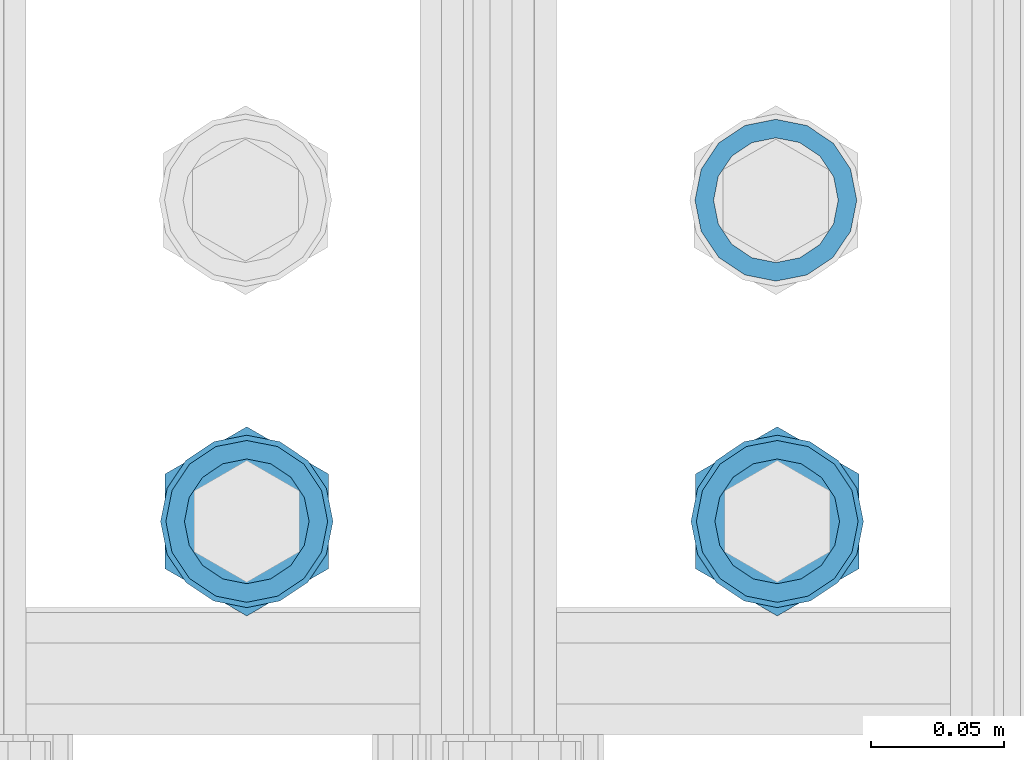
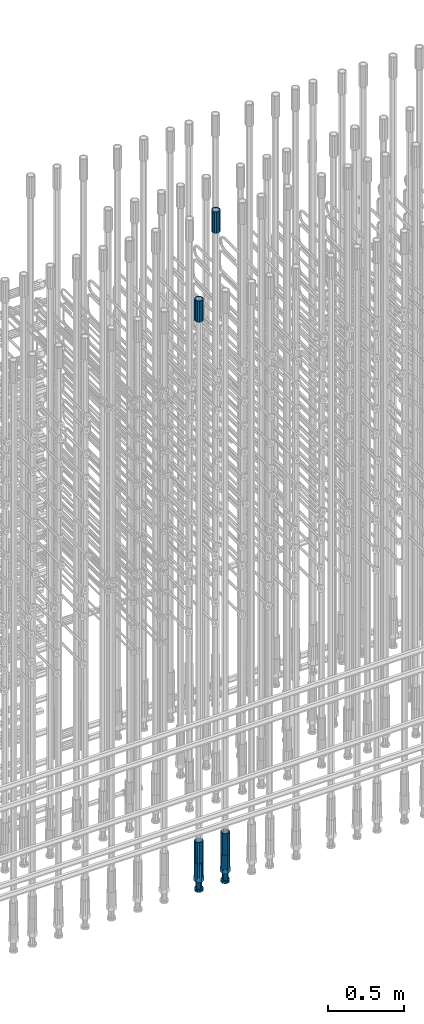
# One storey, part 59 of 177: 6 beams.
"""IFC2X3 building model written with IfcOpenShell, lengths in millimetres."""

from ifc_helpers import new_model, si_unit, frame, origin_with_axes, place, context, subcontext, project, spatial, faceted_brep, material, type_object, element, save


model = new_model("IFC2X3")

# Units and contexts
model_context_1 = context("Model", 3, precision=1e-05, world=origin_with_axes())
model_context_2 = context("Model", 3, precision=1e-05, world=origin_with_axes())
body_context = subcontext(model_context_2, "Body", "Model", "MODEL_VIEW")
ifc_project = project(units=[si_unit("LENGTHUNIT", "METRE", prefix="MILLI"), si_unit("AREAUNIT", "SQUARE_METRE"), si_unit("VOLUMEUNIT", "CUBIC_METRE"), si_unit("MASSUNIT", "GRAM", prefix="KILO"), si_unit("TIMEUNIT", "SECOND"), si_unit("PLANEANGLEUNIT", "RADIAN"), si_unit("SOLIDANGLEUNIT", "STERADIAN"), si_unit("THERMODYNAMICTEMPERATUREUNIT", "DEGREE_CELSIUS"), si_unit("LUMINOUSINTENSITYUNIT", "LUMEN")], contexts=[model_context_1])

# Site, building, storey
site_placement = place(None, origin_with_axes())
site = spatial("IfcSite", under=ifc_project, at=site_placement, CompositionType="ELEMENT")
building_placement = place(site_placement, origin_with_axes())
building = spatial("IfcBuilding", under=site, at=building_placement, Name="Undefined", CompositionType="ELEMENT")
storey_placement = place(building_placement, origin_with_axes())
storey = spatial("IfcBuildingStorey", under=building, at=storey_placement, Name="Undefined", CompositionType="ELEMENT", Elevation=0.0)

# Beams
ifc_material = material(Name="STEEL/S275")
beam_type_1 = type_object("IfcBeamType", PredefinedType="NOTDEFINED")
beam_1_placement = place(storey_placement, frame((2032435.50306268, 6205277.49272666, 23229.9858194793), z_axis=(1.0, 0.0, 0.0), x_axis=(0.0, 0.0, 1.0)))
element("IfcBeam", 1, at=beam_1_placement, inside=storey, type_object=beam_type_1, material=ifc_material, Name="AG40N", context=body_context, shape_type="Brep", body=[
    faceted_brep([(0.0, -23.5000000001164, -9.31322574615479e-10), (0.0, -21.7111690140155, 8.99306066054851), (170.0, -21.7111690140155, 8.99306066054851), (170.0, -23.5, 0.0), (0.0, -16.6170093578839, 16.6170093575493), (170.0, -16.6170093578839, 16.6170093575493), (0.0, -8.99306066057943, 21.7111690137535), (170.0, -8.99306066057943, 21.7111690137535), (0.0, 1.16415321826935e-10, 23.5), (170.0, 0.0, 23.5), (0.0, 8.99306066057943, 21.7111690137535), (170.0, 8.99306066057943, 21.7111690137535), (0.0, 16.6170093578839, 16.6170093575493), (170.0, 16.6170093578839, 16.6170093575493), (0.0, 21.7111690140155, 8.99306066054851), (170.0, 21.7111690140155, 8.99306066054851), (0.0, 23.5000000001164, -9.31322574615479e-10), (170.0, 23.5, 0.0), (0.0, 21.7111690140155, -8.99306066054851), (170.0, 21.7111690140155, -8.99306066054851), (0.0, 16.6170093578839, -16.6170093575493), (170.0, 16.6170093578839, -16.6170093575493), (0.0, 8.99306066057943, -21.7111690137535), (170.0, 8.99306066057943, -21.7111690137535), (0.0, 1.16415321826935e-10, -23.5000000009313), (170.0, 0.0, -23.5), (0.0, -8.99306066057943, -21.7111690137535), (170.0, -8.99306066057943, -21.7111690137535), (0.0, -16.6170093578839, -16.6170093575493), (170.0, -16.6170093578839, -16.6170093575493), (0.0, -21.7111690140155, -8.99306066054851), (170.0, -21.7111690140155, -8.99306066054851), (0.0, -30.5, 0.0), (0.0, -28.1783257415937, -11.6718446873128), (170.0, -28.1783257415937, -11.6718446873128), (170.0, -30.5, 0.0), (0.0, -21.5667568261888, -21.5667568258941), (170.0, -21.5667568261888, -21.5667568258941), (0.0, -11.6718446871346, -28.1783257415518), (170.0, -11.6718446871346, -28.1783257415518), (0.0, 0.0, -30.5), (170.0, 0.0, -30.5), (0.0, 11.6718446871346, -28.1783257415518), (170.0, 11.6718446871346, -28.1783257415518), (0.0, 21.5667568261888, -21.5667568258941), (170.0, 21.5667568261888, -21.5667568258941), (0.0, 28.1783257415937, -11.6718446873128), (170.0, 28.1783257415937, -11.6718446873128), (0.0, 30.5, 0.0), (170.0, 30.5, 0.0), (0.0, 28.1783257415937, 11.6718446873128), (170.0, 28.1783257415937, 11.6718446873128), (0.0, 21.5667568261888, 21.5667568258941), (170.0, 21.5667568261888, 21.5667568258941), (0.0, 11.6718446871346, 28.1783257415518), (170.0, 11.6718446871346, 28.1783257415518), (0.0, 0.0, 30.5), (170.0, 0.0, 30.5), (0.0, -11.6718446871346, 28.1783257415518), (170.0, -11.6718446871346, 28.1783257415518), (0.0, -21.5667568261888, 21.5667568258941), (170.0, -21.5667568261888, 21.5667568258941), (0.0, -28.1783257415937, 11.6718446873128), (170.0, -28.1783257415937, 11.6718446873128)], [[[0, 1, 2, 3]], [[1, 4, 5, 2]], [[4, 6, 7, 5]], [[6, 8, 9, 7]], [[8, 10, 11, 9]], [[10, 12, 13, 11]], [[12, 14, 15, 13]], [[14, 16, 17, 15]], [[16, 18, 19, 17]], [[18, 20, 21, 19]], [[20, 22, 23, 21]], [[22, 24, 25, 23]], [[24, 26, 27, 25]], [[26, 28, 29, 27]], [[28, 30, 31, 29]], [[30, 0, 3, 31]], [[32, 33, 34, 35]], [[33, 36, 37, 34]], [[36, 38, 39, 37]], [[38, 40, 41, 39]], [[40, 42, 43, 41]], [[42, 44, 45, 43]], [[44, 46, 47, 45]], [[46, 48, 49, 47]], [[48, 50, 51, 49]], [[50, 52, 53, 51]], [[52, 54, 55, 53]], [[54, 56, 57, 55]], [[56, 58, 59, 57]], [[58, 60, 61, 59]], [[60, 62, 63, 61]], [[62, 32, 35, 63]], [[37, 39, 41, 43, 45, 47, 49, 51, 53, 55, 57, 59, 61, 63, 35, 34], [5, 7, 9, 11, 13, 15, 17, 19, 21, 23, 25, 27, 29, 31, 3, 2]], [[62, 60, 58, 56, 54, 52, 50, 48, 46, 44, 42, 40, 38, 36, 33, 32], [30, 28, 26, 24, 22, 20, 18, 16, 14, 12, 10, 8, 6, 4, 1, 0]]]),
])
beam_2_placement = place(storey_placement, frame((2032236.00256268, 6205156.4084753, 18490.9668004282), z_axis=(-1.0, 0.0, 0.0), x_axis=(0.0, 0.0, -1.0)))
element("IfcBeam", 2, at=beam_2_placement, inside=storey, type_object=beam_type_1, material=ifc_material, Name="AG40N", context=body_context, shape_type="Brep", body=[
    faceted_brep([(0.0, -23.5000000001164, -9.31322574615479e-10), (0.0, -21.7111690140155, 8.99306066054851), (170.0, -21.7111690140155, 8.99306066054851), (170.0, -23.5, 0.0), (0.0, -16.6170093578839, 16.6170093575493), (170.0, -16.6170093578839, 16.6170093575493), (0.0, -8.99306066057943, 21.7111690137535), (170.0, -8.99306066057943, 21.7111690137535), (0.0, 1.16415321826935e-10, 23.5), (170.0, 0.0, 23.5), (0.0, 8.99306066057943, 21.7111690137535), (170.0, 8.99306066057943, 21.7111690137535), (0.0, 16.6170093578839, 16.6170093575493), (170.0, 16.6170093578839, 16.6170093575493), (0.0, 21.7111690140155, 8.99306066054851), (170.0, 21.7111690140155, 8.99306066054851), (0.0, 23.5000000001164, -9.31322574615479e-10), (170.0, 23.5, 0.0), (0.0, 21.7111690140155, -8.99306066054851), (170.0, 21.7111690140155, -8.99306066054851), (0.0, 16.6170093578839, -16.6170093575493), (170.0, 16.6170093578839, -16.6170093575493), (0.0, 8.99306066057943, -21.7111690137535), (170.0, 8.99306066057943, -21.7111690137535), (0.0, 1.16415321826935e-10, -23.5000000009313), (170.0, 0.0, -23.5), (0.0, -8.99306066057943, -21.7111690137535), (170.0, -8.99306066057943, -21.7111690137535), (0.0, -16.6170093578839, -16.6170093575493), (170.0, -16.6170093578839, -16.6170093575493), (0.0, -21.7111690140155, -8.99306066054851), (170.0, -21.7111690140155, -8.99306066054851), (0.0, -30.5, 0.0), (0.0, -28.1783257415937, -11.6718446873128), (170.0, -28.1783257415937, -11.6718446873128), (170.0, -30.5, 0.0), (0.0, -21.5667568261888, -21.5667568258941), (170.0, -21.5667568261888, -21.5667568258941), (0.0, -11.6718446871346, -28.1783257415518), (170.0, -11.6718446871346, -28.1783257415518), (0.0, 0.0, -30.5), (170.0, 0.0, -30.5), (0.0, 11.6718446871346, -28.1783257415518), (170.0, 11.6718446871346, -28.1783257415518), (0.0, 21.5667568261888, -21.5667568258941), (170.0, 21.5667568261888, -21.5667568258941), (0.0, 28.1783257415937, -11.6718446873128), (170.0, 28.1783257415937, -11.6718446873128), (0.0, 30.5, 0.0), (170.0, 30.5, 0.0), (0.0, 28.1783257415937, 11.6718446873128), (170.0, 28.1783257415937, 11.6718446873128), (0.0, 21.5667568261888, 21.5667568258941), (170.0, 21.5667568261888, 21.5667568258941), (0.0, 11.6718446871346, 28.1783257415518), (170.0, 11.6718446871346, 28.1783257415518), (0.0, 0.0, 30.5), (170.0, 0.0, 30.5), (0.0, -11.6718446871346, 28.1783257415518), (170.0, -11.6718446871346, 28.1783257415518), (0.0, -21.5667568261888, 21.5667568258941), (170.0, -21.5667568261888, 21.5667568258941), (0.0, -28.1783257415937, 11.6718446873128), (170.0, -28.1783257415937, 11.6718446873128)], [[[0, 1, 2, 3]], [[1, 4, 5, 2]], [[4, 6, 7, 5]], [[6, 8, 9, 7]], [[8, 10, 11, 9]], [[10, 12, 13, 11]], [[12, 14, 15, 13]], [[14, 16, 17, 15]], [[16, 18, 19, 17]], [[18, 20, 21, 19]], [[20, 22, 23, 21]], [[22, 24, 25, 23]], [[24, 26, 27, 25]], [[26, 28, 29, 27]], [[28, 30, 31, 29]], [[30, 0, 3, 31]], [[32, 33, 34, 35]], [[33, 36, 37, 34]], [[36, 38, 39, 37]], [[38, 40, 41, 39]], [[40, 42, 43, 41]], [[42, 44, 45, 43]], [[44, 46, 47, 45]], [[46, 48, 49, 47]], [[48, 50, 51, 49]], [[50, 52, 53, 51]], [[52, 54, 55, 53]], [[54, 56, 57, 55]], [[56, 58, 59, 57]], [[58, 60, 61, 59]], [[60, 62, 63, 61]], [[62, 32, 35, 63]], [[37, 39, 41, 43, 45, 47, 49, 51, 53, 55, 57, 59, 61, 63, 35, 34], [5, 7, 9, 11, 13, 15, 17, 19, 21, 23, 25, 27, 29, 31, 3, 2]], [[62, 60, 58, 56, 54, 52, 50, 48, 46, 44, 42, 40, 38, 36, 33, 32], [30, 28, 26, 24, 22, 20, 18, 16, 14, 12, 10, 8, 6, 4, 1, 0]]]),
])
beam_3_placement = place(storey_placement, frame((2032236.00256267, 6205156.40847529, 22659.9858194828), z_axis=(1.0, 0.0, 0.0), x_axis=(0.0, 0.0, 1.0)))
element("IfcBeam", 3, at=beam_3_placement, inside=storey, type_object=beam_type_1, material=ifc_material, Name="AG40N", context=body_context, shape_type="Brep", body=[
    faceted_brep([(0.0, -23.5000000001164, -9.31322574615479e-10), (0.0, -21.7111690140155, 8.99306066054851), (170.0, -21.7111690140155, 8.99306066054851), (170.0, -23.5, 0.0), (0.0, -16.6170093578839, 16.6170093575493), (170.0, -16.6170093578839, 16.6170093575493), (0.0, -8.99306066057943, 21.7111690137535), (170.0, -8.99306066057943, 21.7111690137535), (0.0, 1.16415321826935e-10, 23.5), (170.0, 0.0, 23.5), (0.0, 8.99306066057943, 21.7111690137535), (170.0, 8.99306066057943, 21.7111690137535), (0.0, 16.6170093578839, 16.6170093575493), (170.0, 16.6170093578839, 16.6170093575493), (0.0, 21.7111690140155, 8.99306066054851), (170.0, 21.7111690140155, 8.99306066054851), (0.0, 23.5000000001164, -9.31322574615479e-10), (170.0, 23.5, 0.0), (0.0, 21.7111690140155, -8.99306066054851), (170.0, 21.7111690140155, -8.99306066054851), (0.0, 16.6170093578839, -16.6170093575493), (170.0, 16.6170093578839, -16.6170093575493), (0.0, 8.99306066057943, -21.7111690137535), (170.0, 8.99306066057943, -21.7111690137535), (0.0, 1.16415321826935e-10, -23.5000000009313), (170.0, 0.0, -23.5), (0.0, -8.99306066057943, -21.7111690137535), (170.0, -8.99306066057943, -21.7111690137535), (0.0, -16.6170093578839, -16.6170093575493), (170.0, -16.6170093578839, -16.6170093575493), (0.0, -21.7111690140155, -8.99306066054851), (170.0, -21.7111690140155, -8.99306066054851), (0.0, -30.5, 0.0), (0.0, -28.1783257415937, -11.6718446873128), (170.0, -28.1783257415937, -11.6718446873128), (170.0, -30.5, 0.0), (0.0, -21.5667568261888, -21.5667568258941), (170.0, -21.5667568261888, -21.5667568258941), (0.0, -11.6718446871346, -28.1783257415518), (170.0, -11.6718446871346, -28.1783257415518), (0.0, 0.0, -30.5), (170.0, 0.0, -30.5), (0.0, 11.6718446871346, -28.1783257415518), (170.0, 11.6718446871346, -28.1783257415518), (0.0, 21.5667568261888, -21.5667568258941), (170.0, 21.5667568261888, -21.5667568258941), (0.0, 28.1783257415937, -11.6718446873128), (170.0, 28.1783257415937, -11.6718446873128), (0.0, 30.5, 0.0), (170.0, 30.5, 0.0), (0.0, 28.1783257415937, 11.6718446873128), (170.0, 28.1783257415937, 11.6718446873128), (0.0, 21.5667568261888, 21.5667568258941), (170.0, 21.5667568261888, 21.5667568258941), (0.0, 11.6718446871346, 28.1783257415518), (170.0, 11.6718446871346, 28.1783257415518), (0.0, 0.0, 30.5), (170.0, 0.0, 30.5), (0.0, -11.6718446871346, 28.1783257415518), (170.0, -11.6718446871346, 28.1783257415518), (0.0, -21.5667568261888, 21.5667568258941), (170.0, -21.5667568261888, 21.5667568258941), (0.0, -28.1783257415937, 11.6718446873128), (170.0, -28.1783257415937, 11.6718446873128)], [[[0, 1, 2, 3]], [[1, 4, 5, 2]], [[4, 6, 7, 5]], [[6, 8, 9, 7]], [[8, 10, 11, 9]], [[10, 12, 13, 11]], [[12, 14, 15, 13]], [[14, 16, 17, 15]], [[16, 18, 19, 17]], [[18, 20, 21, 19]], [[20, 22, 23, 21]], [[22, 24, 25, 23]], [[24, 26, 27, 25]], [[26, 28, 29, 27]], [[28, 30, 31, 29]], [[30, 0, 3, 31]], [[32, 33, 34, 35]], [[33, 36, 37, 34]], [[36, 38, 39, 37]], [[38, 40, 41, 39]], [[40, 42, 43, 41]], [[42, 44, 45, 43]], [[44, 46, 47, 45]], [[46, 48, 49, 47]], [[48, 50, 51, 49]], [[50, 52, 53, 51]], [[52, 54, 55, 53]], [[54, 56, 57, 55]], [[56, 58, 59, 57]], [[58, 60, 61, 59]], [[60, 62, 63, 61]], [[62, 32, 35, 63]], [[37, 39, 41, 43, 45, 47, 49, 51, 53, 55, 57, 59, 61, 63, 35, 34], [5, 7, 9, 11, 13, 15, 17, 19, 21, 23, 25, 27, 29, 31, 3, 2]], [[62, 60, 58, 56, 54, 52, 50, 48, 46, 44, 42, 40, 38, 36, 33, 32], [30, 28, 26, 24, 22, 20, 18, 16, 14, 12, 10, 8, 6, 4, 1, 0]]]),
])
beam_4_placement = place(storey_placement, frame((2032436.00256268, 6205156.4084753, 18490.9668004282), z_axis=(-1.0, 0.0, 0.0), x_axis=(0.0, 0.0, -1.0)))
element("IfcBeam", 4, at=beam_4_placement, inside=storey, type_object=beam_type_1, material=ifc_material, Name="AG40N", context=body_context, shape_type="Brep", body=[
    faceted_brep([(0.0, -23.5000000001164, -9.31322574615479e-10), (0.0, -21.7111690140155, 8.99306066054851), (170.0, -21.7111690140155, 8.99306066054851), (170.0, -23.5, 0.0), (0.0, -16.6170093578839, 16.6170093575493), (170.0, -16.6170093578839, 16.6170093575493), (0.0, -8.99306066057943, 21.7111690137535), (170.0, -8.99306066057943, 21.7111690137535), (0.0, 1.16415321826935e-10, 23.5), (170.0, 0.0, 23.5), (0.0, 8.99306066057943, 21.7111690137535), (170.0, 8.99306066057943, 21.7111690137535), (0.0, 16.6170093578839, 16.6170093575493), (170.0, 16.6170093578839, 16.6170093575493), (0.0, 21.7111690140155, 8.99306066054851), (170.0, 21.7111690140155, 8.99306066054851), (0.0, 23.5000000001164, -9.31322574615479e-10), (170.0, 23.5, 0.0), (0.0, 21.7111690140155, -8.99306066054851), (170.0, 21.7111690140155, -8.99306066054851), (0.0, 16.6170093578839, -16.6170093575493), (170.0, 16.6170093578839, -16.6170093575493), (0.0, 8.99306066057943, -21.7111690137535), (170.0, 8.99306066057943, -21.7111690137535), (0.0, 1.16415321826935e-10, -23.5000000009313), (170.0, 0.0, -23.5), (0.0, -8.99306066057943, -21.7111690137535), (170.0, -8.99306066057943, -21.7111690137535), (0.0, -16.6170093578839, -16.6170093575493), (170.0, -16.6170093578839, -16.6170093575493), (0.0, -21.7111690140155, -8.99306066054851), (170.0, -21.7111690140155, -8.99306066054851), (0.0, -30.5, 0.0), (0.0, -28.1783257415937, -11.6718446873128), (170.0, -28.1783257415937, -11.6718446873128), (170.0, -30.5, 0.0), (0.0, -21.5667568261888, -21.5667568258941), (170.0, -21.5667568261888, -21.5667568258941), (0.0, -11.6718446871346, -28.1783257415518), (170.0, -11.6718446871346, -28.1783257415518), (0.0, 0.0, -30.5), (170.0, 0.0, -30.5), (0.0, 11.6718446871346, -28.1783257415518), (170.0, 11.6718446871346, -28.1783257415518), (0.0, 21.5667568261888, -21.5667568258941), (170.0, 21.5667568261888, -21.5667568258941), (0.0, 28.1783257415937, -11.6718446873128), (170.0, 28.1783257415937, -11.6718446873128), (0.0, 30.5, 0.0), (170.0, 30.5, 0.0), (0.0, 28.1783257415937, 11.6718446873128), (170.0, 28.1783257415937, 11.6718446873128), (0.0, 21.5667568261888, 21.5667568258941), (170.0, 21.5667568261888, 21.5667568258941), (0.0, 11.6718446871346, 28.1783257415518), (170.0, 11.6718446871346, 28.1783257415518), (0.0, 0.0, 30.5), (170.0, 0.0, 30.5), (0.0, -11.6718446871346, 28.1783257415518), (170.0, -11.6718446871346, 28.1783257415518), (0.0, -21.5667568261888, 21.5667568258941), (170.0, -21.5667568261888, 21.5667568258941), (0.0, -28.1783257415937, 11.6718446873128), (170.0, -28.1783257415937, 11.6718446873128)], [[[0, 1, 2, 3]], [[1, 4, 5, 2]], [[4, 6, 7, 5]], [[6, 8, 9, 7]], [[8, 10, 11, 9]], [[10, 12, 13, 11]], [[12, 14, 15, 13]], [[14, 16, 17, 15]], [[16, 18, 19, 17]], [[18, 20, 21, 19]], [[20, 22, 23, 21]], [[22, 24, 25, 23]], [[24, 26, 27, 25]], [[26, 28, 29, 27]], [[28, 30, 31, 29]], [[30, 0, 3, 31]], [[32, 33, 34, 35]], [[33, 36, 37, 34]], [[36, 38, 39, 37]], [[38, 40, 41, 39]], [[40, 42, 43, 41]], [[42, 44, 45, 43]], [[44, 46, 47, 45]], [[46, 48, 49, 47]], [[48, 50, 51, 49]], [[50, 52, 53, 51]], [[52, 54, 55, 53]], [[54, 56, 57, 55]], [[56, 58, 59, 57]], [[58, 60, 61, 59]], [[60, 62, 63, 61]], [[62, 32, 35, 63]], [[37, 39, 41, 43, 45, 47, 49, 51, 53, 55, 57, 59, 61, 63, 35, 34], [5, 7, 9, 11, 13, 15, 17, 19, 21, 23, 25, 27, 29, 31, 3, 2]], [[62, 60, 58, 56, 54, 52, 50, 48, 46, 44, 42, 40, 38, 36, 33, 32], [30, 28, 26, 24, 22, 20, 18, 16, 14, 12, 10, 8, 6, 4, 1, 0]]]),
])
beam_type_2 = type_object("IfcBeamType", Name="ROD65", PredefinedType="NOTDEFINED")
beam_5_placement = place(storey_placement, frame((2032236.00256267, 6205156.4084753, 18320.9668004282), z_axis=(-1.0, 0.0, 0.0), x_axis=(0.0, 0.0, -1.0)))
element("IfcBeam", 5, at=beam_5_placement, inside=storey, type_object=beam_type_2, material=ifc_material, Name="AGB40", ObjectType="ROD65", context=body_context, shape_type="Brep", body=[
    faceted_brep([(117.0, 8.17543110251427, 30.873805644922), (117.0, 17.8250000001863, 30.873805644922), (117.0, 22.0056958701462, 23.6326279877685), (117.0, 12.4372115517035, 30.0260848065373), (117.0, -17.8250000001863, 30.873805644922), (150.200000000186, -17.8250000001863, 30.873805644922), (150.200000000186, 17.8250000001863, 30.873805644922), (117.0, -8.17543110251427, 30.873805644922), (117.0, -12.4372115517035, 30.0260848065373), (117.0, -22.0056958701462, 23.6326279877685), (117.0, -35.6500000003725, 0.0), (150.200000000186, -35.6500000003725, 0.0), (117.0, -30.8443150008097, 8.32369058486074), (117.0, -32.5, 0.0), (117.0, -30.8443150008097, -8.32369058462791), (117.0, -17.8250000001863, -30.873805644922), (150.200000000186, -17.8250000001863, -30.873805644922), (117.0, -22.0056958701462, -23.6326279877685), (117.0, -12.4372115517035, -30.0260848065373), (117.0, -8.17543110251427, -30.873805644922), (117.0, 17.8250000001863, -30.873805644922), (150.200000000186, 17.8250000001863, -30.873805644922), (117.0, 8.17543110251427, -30.873805644922), (117.0, 22.0056958701462, -23.6326279877685), (117.0, 12.4372115517035, -30.0260848065373), (117.0, 35.6500000003725, 0.0), (150.200000000186, 35.6500000003725, 0.0), (117.0, 30.8443150008097, -8.32369058486074), (117.0, 30.8443150008097, 8.32369058462791), (117.0, 32.5, 0.0), (0.0, -22.9809703892097, 22.9809703885621), (0.0, -30.0260848058388, 12.4372115518636), (117.0, -30.0260848067701, 12.4372115519363), (117.0, -22.9809703882784, 22.9809703885112), (-2.3283064365387e-10, 22.9809703892097, -22.9809703885639), (-4.65661287307739e-10, 30.0260848077014, -12.4372115518672), (117.0, 30.0260848067701, -12.4372115519363), (117.0, 22.9809703882784, -22.9809703885112), (-2.3283064365387e-10, -30.0260848067701, -12.4372115518672), (-2.3283064365387e-10, -22.9809703892097, -22.9809703885621), (117.0, -22.9809703882784, -22.9809703885112), (117.0, -30.0260848067701, -12.4372115519363), (-2.3283064365387e-10, -12.4372115507722, 30.0260848066137), (-2.3283064365387e-10, 9.31322574615479e-10, 32.4999999999982), (-2.3283064365387e-10, 12.4372115526348, 30.0260848066137), (0.0, 22.9809703892097, 22.9809703885621), (-2.3283064365387e-10, 30.0260848077014, 12.4372115518636), (-2.3283064365387e-10, 32.5, 0.0), (-2.3283064365387e-10, 12.4372115526348, -30.0260848066173), (-2.3283064365387e-10, 9.31322574615479e-10, -32.5), (-2.3283064365387e-10, -12.4372115517035, -30.0260848066173), (-4.65661287307739e-10, -32.4999999990687, -1.81898940354586e-12), (117.0, 22.9809703882784, 22.9809703885112), (117.0, 30.0260848067701, 12.4372115519363), (117.0, 0.0, -32.5), (117.0, 0.0, 32.5), (150.200000000186, 10.5, -18.1865334794857), (150.200000000186, 0.0, -21.0), (150.200000000186, -10.5, -18.1865334794857), (150.200000000186, -18.18653347902, -10.5), (150.200000000186, -21.0, 0.0), (150.200000000186, -18.18653347902, 10.5), (150.200000000186, -10.5, 18.1865334794857), (150.200000000186, 0.0, 21.0), (150.200000000186, 10.5, 18.1865334794857), (150.200000000186, 18.18653347902, 10.5), (150.200000000186, 21.0, 0.0), (150.200000000186, 18.18653347902, -10.5), (210.980000000447, -10.5, -18.1865334794857), (210.980000000447, 0.0, -21.0), (210.980000000447, -18.18653347902, -10.5), (210.980000000447, -21.0, 0.0), (210.980000000447, -18.18653347902, 10.5), (210.980000000447, -10.5, 18.1865334794857), (210.980000000447, 0.0, 21.0), (210.980000000447, 10.5, 18.1865334794857), (210.980000000447, 18.18653347902, 10.5), (210.980000000447, 21.0, 0.0), (210.980000000447, 18.18653347902, -10.5), (210.980000000447, 10.5, -18.1865334794857), (211.001368442696, -27.7269937992096, -11.491116326768), (211.003082550167, -21.2238094303757, -21.223815418547), (231.002518367059, -21.2131944671273, -21.2132004550658), (231.000804259587, -27.7163788359612, -11.4805013632867), (211.001368440451, -11.4911085031927, -27.7269970395137), (231.000804257343, -11.4804935399443, -27.7163820760325), (210.996487071217, -0.0106065049767494, -30.0106107392348), (230.995922888109, 8.45827162265778e-06, -29.9999957757536), (210.989181586672, 11.46989420522, -27.7269970329944), (230.988617403564, 11.4805091684684, -27.7163820695132), (210.980564180623, 21.2025914648548, -21.2238154064398), (230.979999997515, 21.2132064281031, -21.2132004429586), (210.971946775022, 27.7057703435421, -11.4911163107026), (230.971382591913, 27.7163853067905, -11.4805013472214), (210.96464129175, 29.9893808094785, -0.0106149562634528), (230.964077108642, 29.9999957727268, 7.21774995326996e-09), (210.959759924415, 27.7057638689876, 11.4698863970116), (230.959195741307, 27.7163788322359, 11.4805013604928), (210.958045816944, 21.2025795001537, 21.2025854887906), (230.957481633835, 21.213194463402, 21.2132004522718), (210.95975992666, 11.4698785729706, 27.7057671097573), (230.959195743551, 11.480493536219, 27.7163820732385), (210.964641295894, -0.010623425245285, 29.9893808094785), (230.964077112785, -8.46199691295624e-06, 29.9999957729597), (210.971946780439, -11.4911241354421, 27.705767103238), (230.97138259733, -11.4805091721937, 27.7163820667192), (210.980564186488, -21.2238213950768, 21.2025854766835), (230.980000003379, -21.2132064318284, 21.2132004401647), (210.989181592089, -27.7270002737641, 11.4698863809463), (230.988617408981, -27.7163853105158, 11.4805013444275), (210.996487075361, -30.0106107397005, -0.0106149734929204), (230.995922892253, -29.9999957764521, -1.00117176771164e-08)], [[[0, 1, 2, 3]], [[4, 5, 6, 1, 0, 7]], [[4, 7, 8, 9]], [[10, 11, 5, 4, 9, 12]], [[10, 12, 13, 14]], [[15, 16, 11, 10, 14, 17]], [[15, 17, 18, 19]], [[20, 21, 16, 15, 19, 22]], [[23, 20, 22, 24]], [[25, 26, 21, 20, 23, 27]], [[28, 25, 27, 29]], [[30, 31, 32, 33]], [[34, 35, 36, 37]], [[38, 39, 40, 41]], [[31, 30, 42, 43, 44, 45, 46, 47, 35, 34, 48, 49, 50, 39, 38, 51]], [[46, 45, 52, 53]], [[29, 47, 46, 53, 28]], [[27, 36, 35, 47, 29]], [[23, 37, 36, 27]], [[24, 48, 34, 37, 23]], [[22, 54, 49, 48, 24]], [[19, 54, 22]], [[18, 50, 49, 54, 19]], [[17, 40, 39, 50, 18]], [[14, 41, 40, 17]], [[13, 51, 38, 41, 14]], [[12, 32, 31, 51, 13]], [[9, 33, 32, 12]], [[8, 42, 30, 33, 9]], [[7, 55, 43, 42, 8]], [[0, 55, 7]], [[3, 44, 43, 55, 0]], [[2, 52, 45, 44, 3]], [[28, 53, 52, 2]], [[1, 6, 26, 25, 28, 2]], [[5, 11, 16, 21, 26, 6], [56, 57, 58, 59, 60, 61, 62, 63, 64, 65, 66, 67]], [[68, 58, 57, 69]], [[70, 59, 58, 68]], [[71, 60, 59, 70]], [[72, 61, 60, 71]], [[73, 62, 61, 72]], [[74, 63, 62, 73]], [[75, 64, 63, 74]], [[76, 65, 64, 75]], [[77, 66, 65, 76]], [[78, 67, 66, 77]], [[79, 56, 67, 78]], [[69, 57, 56, 79]], [[80, 81, 82, 83]], [[81, 84, 85, 82]], [[84, 86, 87, 85]], [[86, 88, 89, 87]], [[88, 90, 91, 89]], [[90, 92, 93, 91]], [[92, 94, 95, 93]], [[94, 96, 97, 95]], [[96, 98, 99, 97]], [[98, 100, 101, 99]], [[100, 102, 103, 101]], [[102, 104, 105, 103]], [[104, 106, 107, 105]], [[106, 108, 109, 107]], [[108, 110, 111, 109]], [[82, 85, 87, 89, 91, 93, 95, 97, 99, 101, 103, 105, 107, 109, 111, 83]], [[110, 80, 83, 111]], [[108, 106, 104, 102, 100, 98, 96, 94, 92, 90, 88, 86, 84, 81, 80, 110], [78, 77, 76, 75, 74, 73, 72, 71, 70, 68, 69, 79]]]),
])
beam_6_placement = place(storey_placement, frame((2032436.00256267, 6205156.4084753, 18320.9668004282), z_axis=(-1.0, 0.0, 0.0), x_axis=(0.0, 0.0, -1.0)))
element("IfcBeam", 6, at=beam_6_placement, inside=storey, type_object=beam_type_2, material=ifc_material, Name="AGB40", ObjectType="ROD65", context=body_context, shape_type="Brep", body=[
    faceted_brep([(117.0, 8.17543110251427, 30.873805644922), (117.0, 17.8250000001863, 30.873805644922), (117.0, 22.0056958701462, 23.6326279877685), (117.0, 12.4372115517035, 30.0260848065373), (117.0, -17.8250000001863, 30.873805644922), (150.200000000186, -17.8250000001863, 30.873805644922), (150.200000000186, 17.8250000001863, 30.873805644922), (117.0, -8.17543110251427, 30.873805644922), (117.0, -12.4372115517035, 30.0260848065373), (117.0, -22.0056958701462, 23.6326279877685), (117.0, -35.6500000003725, 0.0), (150.200000000186, -35.6500000003725, 0.0), (117.0, -30.8443150008097, 8.32369058486074), (117.0, -32.5, 0.0), (117.0, -30.8443150008097, -8.32369058462791), (117.0, -17.8250000001863, -30.873805644922), (150.200000000186, -17.8250000001863, -30.873805644922), (117.0, -22.0056958701462, -23.6326279877685), (117.0, -12.4372115517035, -30.0260848065373), (117.0, -8.17543110251427, -30.873805644922), (117.0, 17.8250000001863, -30.873805644922), (150.200000000186, 17.8250000001863, -30.873805644922), (117.0, 8.17543110251427, -30.873805644922), (117.0, 22.0056958701462, -23.6326279877685), (117.0, 12.4372115517035, -30.0260848065373), (117.0, 35.6500000003725, 0.0), (150.200000000186, 35.6500000003725, 0.0), (117.0, 30.8443150008097, -8.32369058486074), (117.0, 30.8443150008097, 8.32369058462791), (117.0, 32.5, 0.0), (0.0, -22.9809703892097, 22.9809703885621), (0.0, -30.0260848058388, 12.4372115518636), (117.0, -30.0260848067701, 12.4372115519363), (117.0, -22.9809703882784, 22.9809703885112), (-2.3283064365387e-10, 22.9809703892097, -22.9809703885639), (-4.65661287307739e-10, 30.0260848077014, -12.4372115518672), (117.0, 30.0260848067701, -12.4372115519363), (117.0, 22.9809703882784, -22.9809703885112), (-2.3283064365387e-10, -30.0260848067701, -12.4372115518672), (-2.3283064365387e-10, -22.9809703892097, -22.9809703885621), (117.0, -22.9809703882784, -22.9809703885112), (117.0, -30.0260848067701, -12.4372115519363), (-2.3283064365387e-10, -12.4372115507722, 30.0260848066137), (-2.3283064365387e-10, 9.31322574615479e-10, 32.4999999999982), (-2.3283064365387e-10, 12.4372115526348, 30.0260848066137), (0.0, 22.9809703892097, 22.9809703885621), (-2.3283064365387e-10, 30.0260848077014, 12.4372115518636), (-2.3283064365387e-10, 32.5, 0.0), (-2.3283064365387e-10, 12.4372115526348, -30.0260848066173), (-2.3283064365387e-10, 9.31322574615479e-10, -32.5), (-2.3283064365387e-10, -12.4372115517035, -30.0260848066173), (-4.65661287307739e-10, -32.4999999990687, -1.81898940354586e-12), (117.0, 22.9809703882784, 22.9809703885112), (117.0, 30.0260848067701, 12.4372115519363), (117.0, 0.0, -32.5), (117.0, 0.0, 32.5), (150.200000000186, 10.5, -18.1865334794857), (150.200000000186, 0.0, -21.0), (150.200000000186, -10.5, -18.1865334794857), (150.200000000186, -18.18653347902, -10.5), (150.200000000186, -21.0, 0.0), (150.200000000186, -18.18653347902, 10.5), (150.200000000186, -10.5, 18.1865334794857), (150.200000000186, 0.0, 21.0), (150.200000000186, 10.5, 18.1865334794857), (150.200000000186, 18.18653347902, 10.5), (150.200000000186, 21.0, 0.0), (150.200000000186, 18.18653347902, -10.5), (210.980000000447, -10.5, -18.1865334794857), (210.980000000447, 0.0, -21.0), (210.980000000447, -18.18653347902, -10.5), (210.980000000447, -21.0, 0.0), (210.980000000447, -18.18653347902, 10.5), (210.980000000447, -10.5, 18.1865334794857), (210.980000000447, 0.0, 21.0), (210.980000000447, 10.5, 18.1865334794857), (210.980000000447, 18.18653347902, 10.5), (210.980000000447, 21.0, 0.0), (210.980000000447, 18.18653347902, -10.5), (210.980000000447, 10.5, -18.1865334794857), (211.001368442696, -27.7269937992096, -11.491116326768), (211.003082550167, -21.2238094303757, -21.223815418547), (231.002518367059, -21.2131944671273, -21.2132004550658), (231.000804259587, -27.7163788359612, -11.4805013632867), (211.001368440451, -11.4911085031927, -27.7269970395137), (231.000804257343, -11.4804935399443, -27.7163820760325), (210.996487071217, -0.0106065049767494, -30.0106107392348), (230.995922888109, 8.45827162265778e-06, -29.9999957757536), (210.989181586672, 11.46989420522, -27.7269970329944), (230.988617403564, 11.4805091684684, -27.7163820695132), (210.980564180623, 21.2025914648548, -21.2238154064398), (230.979999997515, 21.2132064281031, -21.2132004429586), (210.971946775022, 27.7057703435421, -11.4911163107026), (230.971382591913, 27.7163853067905, -11.4805013472214), (210.96464129175, 29.9893808094785, -0.0106149562634528), (230.964077108642, 29.9999957727268, 7.21774995326996e-09), (210.959759924415, 27.7057638689876, 11.4698863970116), (230.959195741307, 27.7163788322359, 11.4805013604928), (210.958045816944, 21.2025795001537, 21.2025854887906), (230.957481633835, 21.213194463402, 21.2132004522718), (210.95975992666, 11.4698785729706, 27.7057671097573), (230.959195743551, 11.480493536219, 27.7163820732385), (210.964641295894, -0.010623425245285, 29.9893808094785), (230.964077112785, -8.46199691295624e-06, 29.9999957729597), (210.971946780439, -11.4911241354421, 27.705767103238), (230.97138259733, -11.4805091721937, 27.7163820667192), (210.980564186488, -21.2238213950768, 21.2025854766835), (230.980000003379, -21.2132064318284, 21.2132004401647), (210.989181592089, -27.7270002737641, 11.4698863809463), (230.988617408981, -27.7163853105158, 11.4805013444275), (210.996487075361, -30.0106107397005, -0.0106149734929204), (230.995922892253, -29.9999957764521, -1.00117176771164e-08)], [[[0, 1, 2, 3]], [[4, 5, 6, 1, 0, 7]], [[4, 7, 8, 9]], [[10, 11, 5, 4, 9, 12]], [[10, 12, 13, 14]], [[15, 16, 11, 10, 14, 17]], [[15, 17, 18, 19]], [[20, 21, 16, 15, 19, 22]], [[23, 20, 22, 24]], [[25, 26, 21, 20, 23, 27]], [[28, 25, 27, 29]], [[30, 31, 32, 33]], [[34, 35, 36, 37]], [[38, 39, 40, 41]], [[31, 30, 42, 43, 44, 45, 46, 47, 35, 34, 48, 49, 50, 39, 38, 51]], [[46, 45, 52, 53]], [[29, 47, 46, 53, 28]], [[27, 36, 35, 47, 29]], [[23, 37, 36, 27]], [[24, 48, 34, 37, 23]], [[22, 54, 49, 48, 24]], [[19, 54, 22]], [[18, 50, 49, 54, 19]], [[17, 40, 39, 50, 18]], [[14, 41, 40, 17]], [[13, 51, 38, 41, 14]], [[12, 32, 31, 51, 13]], [[9, 33, 32, 12]], [[8, 42, 30, 33, 9]], [[7, 55, 43, 42, 8]], [[0, 55, 7]], [[3, 44, 43, 55, 0]], [[2, 52, 45, 44, 3]], [[28, 53, 52, 2]], [[1, 6, 26, 25, 28, 2]], [[5, 11, 16, 21, 26, 6], [56, 57, 58, 59, 60, 61, 62, 63, 64, 65, 66, 67]], [[68, 58, 57, 69]], [[70, 59, 58, 68]], [[71, 60, 59, 70]], [[72, 61, 60, 71]], [[73, 62, 61, 72]], [[74, 63, 62, 73]], [[75, 64, 63, 74]], [[76, 65, 64, 75]], [[77, 66, 65, 76]], [[78, 67, 66, 77]], [[79, 56, 67, 78]], [[69, 57, 56, 79]], [[80, 81, 82, 83]], [[81, 84, 85, 82]], [[84, 86, 87, 85]], [[86, 88, 89, 87]], [[88, 90, 91, 89]], [[90, 92, 93, 91]], [[92, 94, 95, 93]], [[94, 96, 97, 95]], [[96, 98, 99, 97]], [[98, 100, 101, 99]], [[100, 102, 103, 101]], [[102, 104, 105, 103]], [[104, 106, 107, 105]], [[106, 108, 109, 107]], [[108, 110, 111, 109]], [[82, 85, 87, 89, 91, 93, 95, 97, 99, 101, 103, 105, 107, 109, 111, 83]], [[110, 80, 83, 111]], [[108, 106, 104, 102, 100, 98, 96, 94, 92, 90, 88, 86, 84, 81, 80, 110], [78, 77, 76, 75, 74, 73, 72, 71, 70, 68, 69, 79]]]),
])

save(model, "model.ifc")
